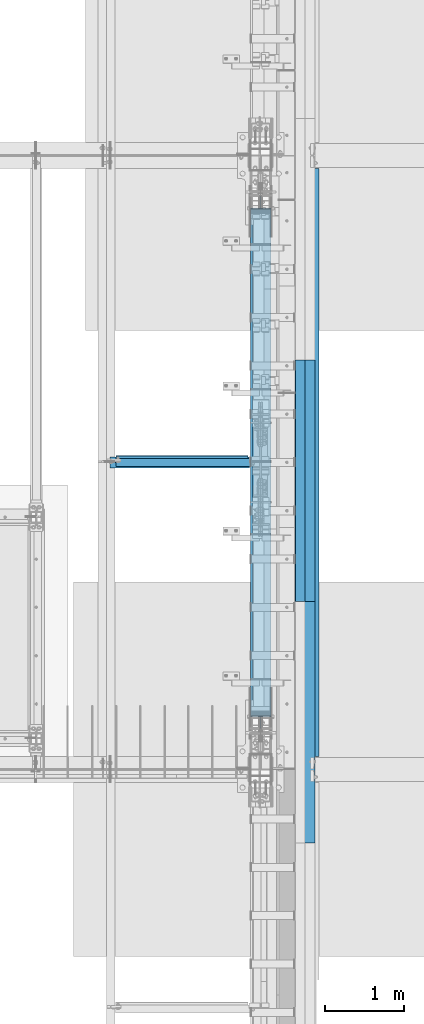
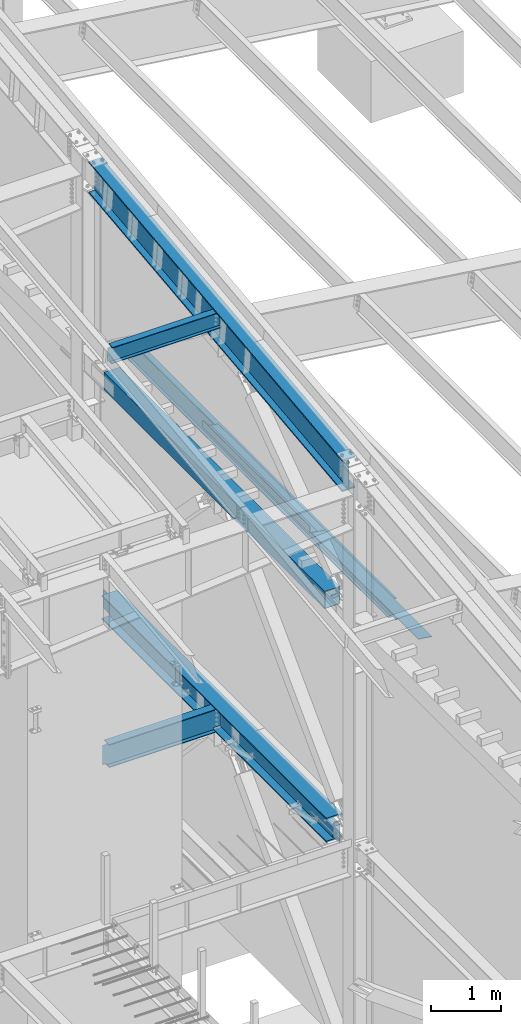
# One storey, part 724 of 1179: 9 beams, 9 elements without a shape of their own.
"""IFC2X3 building model written with IfcOpenShell, lengths in millimetres."""

from ifc_helpers import new_model, si_unit, frame, origin_with_axes, place, context, subcontext, project, spatial, faceted_brep, material, type_object, element, aggregate, save


model = new_model("IFC2X3")

# Units and contexts
model_context = context("Model", 3, precision=1e-05, world=origin_with_axes())
body_context = subcontext(model_context, "Body", "Model", "MODEL_VIEW")
ifc_project = project(units=[si_unit("LENGTHUNIT", "METRE", prefix="MILLI"), si_unit("AREAUNIT", "SQUARE_METRE"), si_unit("VOLUMEUNIT", "CUBIC_METRE"), si_unit("MASSUNIT", "GRAM", prefix="KILO"), si_unit("TIMEUNIT", "SECOND"), si_unit("PLANEANGLEUNIT", "RADIAN"), si_unit("SOLIDANGLEUNIT", "STERADIAN"), si_unit("THERMODYNAMICTEMPERATUREUNIT", "DEGREE_CELSIUS"), si_unit("LUMINOUSINTENSITYUNIT", "LUMEN")], contexts=[model_context])

# Site, building, storey
site_placement = place(None, origin_with_axes())
site = spatial("IfcSite", under=ifc_project, at=site_placement, CompositionType="ELEMENT")
building_placement = place(site_placement, origin_with_axes())
building = spatial("IfcBuilding", under=site, at=building_placement, Name="Undefined", CompositionType="ELEMENT")
storey_placement = place(building_placement, origin_with_axes())
storey = spatial("IfcBuildingStorey", under=building, at=storey_placement, Name="Undefined", CompositionType="ELEMENT", Elevation=0.0)

# Assembly, beam
assembly_1_placement = place(storey_placement, origin_with_axes())
assembly_1 = element("IfcElementAssembly", 1, at=assembly_1_placement, inside=storey, Name="BEAM", AssemblyPlace="NOTDEFINED", PredefinedType="RIGID_FRAME")
ifc_material_1 = material(Name="STEEL/A992")
beam_type_1 = type_object("IfcBeamType", Name="W16X31", PredefinedType="NOTDEFINED")
beam_1_placement = place(assembly_1_placement, frame((22323.425, 15354.3, 3900.4875), z_axis=(0.0, 0.0, 1.0), x_axis=(1.0, 0.0, 0.0)))
beam_1 = element("IfcBeam", 2, at=beam_1_placement, type_object=beam_type_1, material=ifc_material_1, Name="BEAM", ObjectType="W16X31", context=body_context, shape_type="Brep", body=[
    faceted_brep([(19.0499999999993, -3.17499999999927, -169.8625), (19.0499999999993, 3.17499999999927, -169.8625), (73.0250001907261, 3.17499999999927, -169.8625), (73.0250001907261, -3.17499999999927, -169.8625), (77.8850797087725, 3.17499999999927, -170.829229922588), (77.8850797087725, -3.17499999999927, -170.829229922588), (82.0052561769262, 3.17499999999927, -173.582243823066), (82.0052561769262, -3.17499999999927, -173.582243823066), (84.7582700774037, 3.17499999999927, -177.70242029122), (84.7582700774037, -3.17499999999927, -177.70242029122), (85.7249999999913, -3.17499999999927, -182.562499809265), (85.7249999999913, 3.17499999999927, -182.562499809265), (85.7249999999913, 3.17499999999927, -190.5), (85.7249999999913, 69.8500000000004, -190.5), (85.7249999999913, 69.8500000000004, -201.6125), (85.7249999999913, -69.8500000000004, -201.6125), (85.7249999999913, -69.8500000000004, -190.5), (85.7249999999913, -3.17499999999927, -190.5), (1842.29375, 69.8500000000004, 190.5), (1842.29375, 3.17499999999927, 190.5), (85.7249999999913, 3.17499999999927, 190.5), (85.7249999999913, 69.8500000000004, 190.5), (73.0250001907261, -3.17499999999927, 169.8625), (73.0250001907261, 3.17499999999927, 169.8625), (19.0500000762049, 3.17499999999382, 169.8625), (19.0499999238054, -3.17500000000564, 169.8625), (77.8850797087725, -3.17499999999927, 170.829229922588), (77.8850797087725, 3.17499999999927, 170.829229922588), (82.0052561769262, -3.17499999999927, 173.582243823066), (82.0052561769262, 3.17499999999927, 173.582243823066), (84.7582700774037, -3.17499999999927, 177.702420291219), (84.7582700774037, 3.17499999999927, 177.702420291219), (85.7249999999913, -3.17499999999927, 182.562499809265), (85.7249999999913, 3.17499999999927, 182.562499809265), (1842.29375, -69.8500000000004, 201.6125), (1842.29375, 69.8500000000004, 201.6125), (85.7249999999913, 69.8500000000004, 201.6125), (85.7249999999913, -69.8500000000004, 201.6125), (1842.29375, -69.8500000000004, 190.5), (85.7249999999913, -69.8500000000004, 190.5), (1842.29375, -3.17499999999927, 190.5), (85.7249999999913, -3.17499999999927, 190.5), (1842.29375, -3.17499999999927, 169.862499809265), (1842.29375, 3.17499999999927, 169.862499809265), (1843.26047992258, -3.17499999999927, 165.00242029122), (1843.26047992258, 3.17499999999927, 165.00242029122), (1846.01349382306, -3.17499999999927, 160.882243823066), (1846.01349382306, 3.17499999999927, 160.882243823066), (1850.13367029122, -3.17499999999927, 158.129229922588), (1850.13367029122, 3.17499999999927, 158.129229922588), (1854.99374980926, -3.17499999999927, 157.1625), (1854.99374980926, 3.17499999999927, 157.1625), (1966.11875, -3.17499999999927, 157.1625), (1966.11875, 3.17499999999927, 157.1625), (1966.11875, -3.17499999999927, -157.1625), (1966.11875, 3.17499999999927, -157.1625), (1854.99374980926, -3.17499999999927, -157.1625), (1854.99374980926, 3.17499999999927, -157.1625), (1850.13367029122, -3.17499999999927, -158.129229922588), (1850.13367029122, 3.17499999999927, -158.129229922588), (1846.01349382306, -3.17499999999927, -160.882243823066), (1846.01349382306, 3.17499999999927, -160.882243823066), (1843.26047992258, -3.17499999999927, -165.00242029122), (1843.26047992258, 3.17499999999927, -165.00242029122), (1842.29375, -3.17499999999927, -169.862499809266), (1842.29375, 3.17499999999927, -169.862499809266), (1842.29375, -3.17499999999927, -190.5), (1842.29375, -69.8500000000004, -190.5), (1842.29375, -69.8500000000004, -201.6125), (1842.29375, 69.8500000000004, -201.6125), (1842.29375, 69.8500000000004, -190.5), (1842.29375, 3.17499999999927, -190.5)], [[[0, 1, 2, 3]], [[3, 2, 4, 5]], [[5, 4, 6, 7]], [[7, 6, 8, 9]], [[10, 11, 12, 13, 14, 15, 16, 17]], [[9, 8, 11, 10]], [[18, 19, 20, 21]], [[22, 23, 24, 25]], [[26, 27, 23, 22]], [[28, 29, 27, 26]], [[30, 31, 29, 28]], [[32, 33, 31, 30]], [[34, 35, 36, 37]], [[38, 34, 37, 39]], [[40, 38, 39, 41]], [[37, 36, 21, 20, 33, 32, 41, 39]], [[35, 18, 21, 36]], [[34, 38, 40, 42, 43, 19, 18, 35]], [[44, 45, 43, 42]], [[46, 47, 45, 44]], [[48, 49, 47, 46]], [[50, 51, 49, 48]], [[52, 53, 51, 50]], [[53, 52, 54, 55]], [[54, 56, 57, 55]], [[58, 59, 57, 56]], [[60, 61, 59, 58]], [[62, 63, 61, 60]], [[64, 65, 63, 62]], [[66, 67, 68, 69, 70, 71, 65, 64]], [[67, 66, 17, 16]], [[68, 67, 16, 15]], [[69, 68, 15, 14]], [[70, 69, 14, 13]], [[71, 70, 13, 12]], [[6, 4, 2, 1, 24, 23, 27, 29, 31, 33, 20, 19, 43, 45, 47, 49, 51, 53, 55, 57, 59, 61, 63, 65, 71, 12, 11, 8]], [[25, 24, 1, 0]], [[66, 64, 62, 60, 58, 56, 54, 52, 50, 48, 46, 44, 42, 40, 41, 32, 30, 28, 26, 22, 25, 0, 3, 5, 7, 9, 10, 17]]]),
])
aggregate(assembly_1, [beam_1])

assembly_2_placement = place(storey_placement, origin_with_axes())
assembly_2 = element("IfcElementAssembly", 3, at=assembly_2_placement, inside=storey, Name="PLATE", AssemblyPlace="NOTDEFINED", PredefinedType="RIGID_FRAME")
ifc_material_2 = material(Name="STEEL/A36")
beam_type_2 = type_object("IfcBeamType", PredefinedType="NOTDEFINED")
beam_2_placement = place(assembly_2_placement, frame((24880.9652345644, 13601.6999999996, 7964.0487255808), z_axis=(-0.99100656978554, 0.0, 0.133813222971043), x_axis=(0.0, 1.0, 0.0)))
beam_2 = element("IfcBeam", 4, at=beam_2_placement, type_object=beam_type_2, material=ifc_material_2, Name="PLATE", context=body_context, shape_type="Brep", body=[
    faceted_brep([(0.0, 4.76249999999709, -114.3), (0.0, 4.76249999999709, 114.3), (3048.0, 4.76249999996799, 114.300000000025), (3048.0, 4.76250000002983, -114.300000000025), (0.0, -4.76249999999709, 114.3), (3048.0, -4.76250000003711, 114.300000000014), (0.0, -4.76249999999709, -114.3), (3048.0, -4.76249999997344, -114.300000000036)], [[[0, 1, 2, 3]], [[1, 4, 5, 2]], [[4, 6, 7, 5]], [[6, 0, 3, 7]], [[5, 7, 3, 2]], [[6, 4, 1, 0]]]),
])
aggregate(assembly_2, [beam_2])

assembly_3_placement = place(storey_placement, origin_with_axes())
assembly_3 = element("IfcElementAssembly", 5, at=assembly_3_placement, inside=storey, Name="PLATE", AssemblyPlace="NOTDEFINED", PredefinedType="RIGID_FRAME")
beam_3_placement = place(assembly_3_placement, frame((24880.9652345644, 10553.6999999996, 7964.0487255808), z_axis=(-0.99100656978554, 0.0, 0.133813222971043), x_axis=(0.0, 1.0, 0.0)))
beam_3 = element("IfcBeam", 6, at=beam_3_placement, type_object=beam_type_2, material=ifc_material_2, Name="PLATE", context=body_context, shape_type="Brep", body=[
    faceted_brep([(0.0, 4.76249999999709, -114.3), (0.0, 4.76249999999709, 114.3), (3048.0, 4.76249999996799, 114.300000000025), (3048.0, 4.76250000002983, -114.300000000025), (0.0, -4.76249999999709, 114.3), (3048.0, -4.76250000003711, 114.300000000014), (0.0, -4.76249999999709, -114.3), (3048.0, -4.76249999997344, -114.300000000036)], [[[0, 1, 2, 3]], [[1, 4, 5, 2]], [[4, 6, 7, 5]], [[6, 0, 3, 7]], [[5, 7, 3, 2]], [[6, 4, 1, 0]]]),
])
aggregate(assembly_3, [beam_3])

assembly_4_placement = place(storey_placement, origin_with_axes())
assembly_4 = element("IfcElementAssembly", 7, at=assembly_4_placement, inside=storey, Name="BENT_PLATE", AssemblyPlace="NOTDEFINED", PredefinedType="RIGID_FRAME")
beam_type_3 = type_object("IfcBeamType", PredefinedType="NOTDEFINED")
beam_4_placement = place(assembly_4_placement, frame((24744.362499997, 15125.6999999996, 8102.29217706219), z_axis=(0.0, 1.0, 0.0), x_axis=(0.0, 0.0, -1.0)))
beam_4 = element("IfcBeam", 8, at=beam_4_placement, type_object=beam_type_3, material=ifc_material_2, Name="BENT_PLATE", context=body_context, shape_type="Brep", body=[
    faceted_brep([(-2.91038304567337e-11, -4.76250000000073, -1524.0), (-2.91038304567337e-11, -4.76250000000073, 1524.0), (2.91038304567337e-11, 4.76250000000073, 1524.0), (2.91038304567337e-11, 4.76250000000073, -1524.0), (114.300008765535, 4.76250001759399, 1524.0000000001), (114.300003051474, 4.7625000005828, -1524.0), (105.977955544956, -4.76249999945867, -1524.0), (105.977955544956, -4.76249999945867, 1524.0), (131.343048095475, -121.088742065571, 1524.0), (131.343048095475, -121.088742065571, -1524.0), (121.904205090902, -122.366970423507, 1524.0), (121.904205090902, -122.366970423507, -1524.0)], [[[0, 1, 2, 3]], [[3, 2, 4, 5]], [[1, 0, 6, 7]], [[5, 4, 8, 9]], [[4, 2, 1, 7, 10, 8]], [[7, 6, 11, 10]], [[6, 0, 3, 5, 9, 11]], [[10, 11, 9, 8]]]),
])
aggregate(assembly_4, [beam_4])

assembly_5_placement = place(storey_placement, origin_with_axes())
assembly_5 = element("IfcElementAssembly", 9, at=assembly_5_placement, inside=storey, Name="BEAM", AssemblyPlace="NOTDEFINED", PredefinedType="RIGID_FRAME")
beam_type_4 = type_object("IfcBeamType", Name="W12X22", PredefinedType="NOTDEFINED")
beam_5_placement = place(assembly_5_placement, frame((22415.5, 15371.7685968403, 10827.304499945), z_axis=(0.0, -0.112284087038017, 0.993676146336441), x_axis=(1.0, 0.0, 0.0)))
beam_5 = element("IfcBeam", 10, at=beam_5_placement, type_object=beam_type_4, material=ifc_material_1, Name="BEAM", ObjectType="W12X22", context=body_context, shape_type="Brep", body=[
    faceted_brep([(15.875, -3.17500000004293, -130.175000001276), (15.875, 3.17499999995198, -130.175000001278), (50.8000001907349, 3.17499998291896, -130.175000001278), (50.8000001907349, -3.17500000004293, -130.175000001276), (55.6600797087813, 3.17499998284256, -131.141729923866), (55.6600797087813, -3.17500000004293, -131.141729923862), (59.7802561769349, 3.17499998263156, -133.894743824338), (59.7802561769349, -3.17500000004293, -133.894743824334), (62.5332700774125, 3.17499998230778, -138.014920292484), (62.5332700774125, -3.17500000004657, -138.014920292482), (63.5, -3.17500000004657, -142.874999810521), (63.5, 3.17499998193671, -142.874999810523), (63.5, 3.17499995250182, -144.46249999992), (63.5, 50.7999999999192, -144.46249999994), (63.5, 50.7999999999156, -155.574999999932), (63.5, -50.8000000000284, -155.574999999892), (63.5, -50.8000000000247, -144.462499999896), (63.5, -3.1750000000502, -144.462499999914), (1732.75625, 3.17499999994834, -144.46249999992), (1732.75625, 3.17499999999563, -155.574999999912), (1732.75625, 50.7999999999156, -155.574999999932), (1732.75625, 50.7999999999192, -144.46249999994), (1872.45625, 3.17499999994834, -144.46249999992), (1872.45625, 3.17499999999563, -155.574999999912), (1770.85625, 50.8000000000357, 144.4624999999), (1770.85625, 3.17500000006476, 144.462499999918), (63.5, 3.17500000006476, 144.462499999918), (63.5, 50.8000000000357, 144.4624999999), (50.8000001907349, -3.17499999994106, 130.174999998288), (50.8000001907349, 3.17500000292785, 130.174999998286), (15.875, 3.17500000005748, 130.174999998284), (15.875, -3.17499999994106, 130.174999998288), (55.6600797087813, -3.17499999993379, 131.141729920873), (55.6600797087813, 3.17500000300424, 131.141729920872), (59.7802561769349, -3.17499999993743, 133.894743821347), (59.7802561769349, 3.17500000321525, 133.894743821344), (62.5332700774125, -3.17499999993379, 138.014920289494), (62.5332700774125, 3.17500000353539, 138.014920289492), (63.5, -3.17499999993015, 142.874999807531), (63.5, 3.1750000039101, 142.874999807529), (1770.85625, -50.799999999901, 155.574999999935), (1770.85625, 50.8000000000429, 155.574999999893), (63.5, 50.8000000000429, 155.574999999893), (63.5, -50.799999999901, 155.574999999935), (1770.85625, -50.7999999999047, 144.462499999941), (63.5, -50.7999999999047, 144.462499999941), (1770.85625, -3.17499999993379, 144.462499999923), (63.5, -3.17499999993379, 144.462499999923), (1770.85625, -3.17499999993743, 130.174999807548), (1770.85625, 3.17500000005748, 130.174999807547), (1771.82297992259, -3.17499999993743, 125.314920289511), (1771.82297992259, 3.17500000005748, 125.314920289509), (1774.57599382307, -3.1749999999447, 121.194743821365), (1774.57599382307, 3.17500000005384, 121.194743821363), (1778.69617029122, -3.1749999999447, 118.441729920891), (1778.69617029122, 3.17500000005384, 118.441729920889), (1783.55624980927, -3.1749999999447, 117.474999998307), (1783.55624980927, 3.17500000005384, 117.474999998303), (1872.45625, -3.1749999999447, 117.474999998307), (1872.45625, 3.17500000005384, 117.474999998303), (1872.45625, -3.1750000000502, -144.462499999914), (1872.45625, -50.8000000000247, -144.462499999896), (1872.45625, -50.8000000000284, -155.574999999892)], [[[0, 1, 2, 3]], [[3, 2, 4, 5]], [[5, 4, 6, 7]], [[7, 6, 8, 9]], [[10, 11, 12, 13, 14, 15, 16, 17]], [[9, 8, 11, 10]], [[18, 19, 20, 21]], [[22, 23, 19, 18]], [[24, 25, 26, 27]], [[28, 29, 30, 31]], [[32, 33, 29, 28]], [[34, 35, 33, 32]], [[36, 37, 35, 34]], [[38, 39, 37, 36]], [[40, 41, 42, 43]], [[44, 40, 43, 45]], [[46, 44, 45, 47]], [[43, 42, 27, 26, 39, 38, 47, 45]], [[41, 24, 27, 42]], [[40, 44, 46, 48, 49, 25, 24, 41]], [[50, 51, 49, 48]], [[52, 53, 51, 50]], [[54, 55, 53, 52]], [[56, 57, 55, 54]], [[58, 59, 57, 56]], [[60, 61, 62, 23, 22, 59, 58]], [[61, 60, 17, 16]], [[62, 61, 16, 15]], [[20, 19, 23, 62, 15, 14]], [[21, 20, 14, 13]], [[18, 21, 13, 12]], [[6, 4, 2, 1, 30, 29, 33, 35, 37, 39, 26, 25, 49, 51, 53, 55, 57, 59, 22, 18, 12, 11, 8]], [[31, 30, 1, 0]], [[60, 58, 56, 54, 52, 50, 48, 46, 47, 38, 36, 34, 32, 28, 31, 0, 3, 5, 7, 9, 10, 17]]]),
])
aggregate(assembly_5, [beam_5])

assembly_6_placement = place(storey_placement, origin_with_axes())
assembly_6 = element("IfcElementAssembly", 11, at=assembly_6_placement, inside=storey, Name="BEAM", AssemblyPlace="NOTDEFINED", PredefinedType="RIGID_FRAME")
beam_6_placement = place(assembly_6_placement, frame((24972.7820076571, 11480.8, 7789.85835826085), z_axis=(0.133813223953133, 0.0, 0.991006569652931), x_axis=(0.0, 1.0, 0.0)))
beam_6 = element("IfcBeam", 12, at=beam_6_placement, type_object=beam_type_4, material=ifc_material_1, Name="BEAM", ObjectType="W12X22", context=body_context, shape_type="Brep", body=[
    faceted_brep([(7585.075, -3.17499999982829, -144.462500000047), (7585.075, -50.7999999998428, -144.46250000006), (7585.075, -50.7999999998356, -155.575000000064), (7585.075, 50.8000000001921, -155.575000000037), (7585.075, 50.8000000001775, -144.462500000032), (7585.075, 3.17500000017026, -144.462500000047), (7585.075, 3.17500000016298, -136.524999801413), (7585.075, -3.17499999984284, -136.52499980141), (7586.04172992259, 3.17500000014843, -131.664920283363), (7586.04172992259, -3.17499999984284, -131.66492028336), (7588.79474382307, 3.17500000014843, -127.544743815206), (7588.79474382307, -3.17499999985012, -127.544743815202), (7592.91492029122, 3.17500000014843, -124.791729914725), (7592.91492029122, -3.17499999985012, -124.791729914721), (7597.77499980927, 3.17500000014115, -123.824999992135), (7597.77499980927, -3.17499999985739, -123.824999992132), (7726.3625, -3.17499999985739, -123.824999992028), (7726.3625, 3.17500000014115, -123.824999992019), (165.100000000002, 3.17499999982829, 144.462500000052), (165.100000000002, 50.7999999998356, 144.462500000065), (7585.075, 50.7999999998356, 144.462500000065), (7585.075, 3.17499999982829, 144.462500000052), (165.100000000002, -3.17499999984284, -136.524999799762), (165.100000000002, 3.17500000016298, -136.524999799765), (165.100000000002, 3.17500000017026, -144.462500000047), (165.100000000002, 50.8000000001775, -144.462500000032), (165.100000000002, 50.8000000001921, -155.575000000037), (165.100000000002, -50.7999999998356, -155.575000000064), (165.100000000002, -50.7999999998428, -144.46250000006), (165.100000000002, -3.17499999982829, -144.462500000047), (164.133270077415, -3.17499999984284, -131.664920281712), (164.133270077415, 3.17500000014843, -131.664920281715), (161.380256176937, -3.17499999985739, -127.544743813552), (161.380256176937, 3.17500000014843, -127.544743813558), (157.260079708783, -3.17499999985739, -124.791729913073), (157.260079708783, 3.17500000014115, -124.791729913077), (152.400000190737, -3.17499999985739, -123.824999990484), (152.400000190737, 3.17500000014843, -123.824999990487), (20.6375000000044, -3.17499999985739, -123.824999990466), (20.6375000000044, 3.17500000014843, -123.824999990458), (20.6375000000044, -3.17500000014115, 117.475000009781), (20.6375000000044, 3.17499999986467, 117.475000009788), (152.400000190737, -3.17500000014115, 117.475000009763), (152.400000190737, 3.17499999985739, 117.475000009759), (157.260079708783, -3.17500000014115, 118.44172993235), (157.260079708783, 3.17499999986467, 118.441729932347), (161.380256176937, -3.17500000014115, 121.194743832832), (161.380256176937, 3.17499999985739, 121.194743832826), (164.133270077415, -3.17500000014843, 125.314920300991), (164.133270077415, 3.17499999985012, 125.314920300985), (165.100000000002, -3.17500000016298, 130.174999819041), (165.100000000002, 3.17499999984284, 130.174999819037), (165.100000000002, -50.8000000001994, 155.575000000043), (165.100000000002, 50.7999999998283, 155.57500000007), (165.100000000002, -3.17500000017753, 144.462500000051), (165.100000000002, -50.8000000001775, 144.462500000036), (7585.075, -3.17500000017753, 144.462500000051), (7585.075, -50.8000000001775, 144.462500000036), (7585.075, -50.8000000001994, 155.575000000043), (7585.075, 50.7999999998283, 155.57500000007), (7585.075, -3.17500000015571, 130.174999817393), (7585.075, 3.17499999985012, 130.174999817389), (7586.04172992259, -3.17500000015571, 125.314920299345), (7586.04172992259, 3.17499999985012, 125.314920299339), (7588.79474382307, -3.17500000014843, 121.194743831185), (7588.79474382307, 3.17499999985739, 121.194743831182), (7592.91492029122, -3.17500000014115, 118.441729930704), (7592.91492029122, 3.17499999986467, 118.441729930701), (7597.77499980927, -3.17500000014115, 117.475000008117), (7597.77499980927, 3.17499999986467, 117.475000008111), (7726.3625, -3.17500000014115, 117.47500000822), (7726.3625, 3.17499999985739, 117.475000008229)], [[[0, 1, 2, 3, 4, 5, 6, 7]], [[7, 6, 8, 9]], [[9, 8, 10, 11]], [[11, 10, 12, 13]], [[13, 12, 14, 15]], [[16, 15, 14, 17]], [[18, 19, 20, 21]], [[22, 23, 24, 25, 26, 27, 28, 29]], [[30, 31, 23, 22]], [[32, 33, 31, 30]], [[34, 35, 33, 32]], [[36, 37, 35, 34]], [[38, 39, 37, 36]], [[40, 41, 39, 38]], [[42, 43, 41, 40]], [[44, 45, 43, 42]], [[46, 47, 45, 44]], [[48, 49, 47, 46]], [[50, 51, 49, 48]], [[52, 53, 19, 18, 51, 50, 54, 55]], [[55, 54, 56, 57]], [[52, 55, 57, 58]], [[53, 52, 58, 59]], [[19, 53, 59, 20]], [[58, 57, 56, 60, 61, 21, 20, 59]], [[62, 63, 61, 60]], [[64, 65, 63, 62]], [[66, 67, 65, 64]], [[68, 69, 67, 66]], [[70, 71, 69, 68]], [[71, 70, 16, 17]], [[12, 10, 8, 6, 5, 24, 23, 31, 33, 35, 37, 39, 41, 43, 45, 47, 49, 51, 18, 21, 61, 63, 65, 67, 69, 71, 17, 14]], [[25, 24, 5, 4]], [[26, 25, 4, 3]], [[27, 26, 3, 2]], [[28, 27, 2, 1]], [[29, 28, 1, 0]], [[70, 68, 66, 64, 62, 60, 56, 54, 50, 48, 46, 44, 42, 40, 38, 36, 34, 32, 30, 22, 29, 0, 7, 9, 11, 13, 15, 16]]]),
])
aggregate(assembly_6, [beam_6])

assembly_7_placement = place(storey_placement, origin_with_axes())
assembly_7 = element("IfcElementAssembly", 13, at=assembly_7_placement, inside=storey, Name="BEAM", AssemblyPlace="NOTDEFINED", PredefinedType="RIGID_FRAME")
beam_type_5 = type_object("IfcBeamType", Name="W21X93", PredefinedType="NOTDEFINED")
beam_7_placement = place(assembly_7_placement, frame((24307.8, 11511.6467563166, 10271.2956244622), z_axis=(0.0, -0.112284087038017, 0.993676146336441), x_axis=(0.0, 0.993676146336441, 0.112284087038017)))
beam_7 = element("IfcBeam", 14, at=beam_7_placement, type_object=beam_type_5, material=ifc_material_1, Name="BEAM", ObjectType="W21X93", context=body_context, shape_type="Brep", body=[
    faceted_brep([(199.930151815766, -106.362499999999, -274.637499999924), (199.930151815766, 106.362499999999, -274.637499999924), (7473.81664542463, 106.362499999999, -274.637500002875), (7473.81664542463, -106.362499999999, -274.637500002875), (202.620932743182, -106.362499999999, -250.824999999939), (202.620932743182, -7.14374999999927, -250.824999999939), (259.306717614098, -7.14374999999927, 250.824999999757), (259.306717614098, -106.362499999999, 250.824999999757), (261.997498541514, -106.362499999999, 274.637499999742), (261.997498541514, 106.362499999999, 274.637499999742), (259.306717614098, 106.362499999999, 250.824999999757), (259.306717614098, 7.14374999999927, 250.824999999757), (259.165541301165, 7.14374999999927, 249.575637438333), (214.511782852362, 7.14374999999927, -145.595003258246), (202.620932743182, 7.14374999999927, -250.824999999939), (202.620932743182, 106.362499999999, -250.824999999939), (7476.50742635205, -106.362499999999, -250.825000002889), (7476.50742635205, -7.14374999999927, -250.825000002889), (7533.19321122296, -7.14374999999927, 250.824999996807), (7533.19321122296, -106.362499999999, 250.824999996807), (7535.88399215038, -106.362499999999, 274.637499996792), (7535.88399215038, 106.362499999999, 274.637499996792), (7533.19321122296, 106.362499999999, 250.824999996807), (7533.19321122296, 7.14374999999927, 250.824999996807), (7527.16214315235, 7.14374999999927, 197.452089936314), (7482.5083847036, 7.14374999999927, -197.718550759804), (7476.50742635205, 7.14374999999927, -250.825000002889), (7476.50742635205, 106.362499999999, -250.825000002889)], [[[0, 1, 2, 3]], [[0, 4, 5, 6, 7, 8, 9, 10, 11, 12, 13, 14, 15, 1]], [[5, 4, 16, 17]], [[6, 5, 17, 18]], [[7, 6, 18, 19]], [[8, 7, 19, 20]], [[9, 8, 20, 21]], [[10, 9, 21, 22]], [[11, 10, 22, 23]], [[14, 13, 12, 11, 23, 24, 25, 26]], [[15, 14, 26, 27]], [[1, 15, 27, 2]], [[26, 25, 24, 23, 22, 21, 20, 19, 18, 17, 16, 3, 2, 27]], [[4, 0, 3, 16]]]),
])
aggregate(assembly_7, [beam_7])

assembly_8_placement = place(storey_placement, origin_with_axes())
assembly_8 = element("IfcElementAssembly", 15, at=assembly_8_placement, inside=storey, Name="BEAM", AssemblyPlace="NOTDEFINED", PredefinedType="RIGID_FRAME")
beam_type_6 = type_object("IfcBeamType", Name="W16X77", PredefinedType="NOTDEFINED")
beam_8_placement = place(assembly_8_placement, frame((24307.8, 11480.8, 3892.55), z_axis=(0.0, 0.0, 1.0), x_axis=(0.0, 1.0, 0.0)))
beam_8 = element("IfcBeam", 16, at=beam_8_placement, type_object=beam_type_6, material=ifc_material_1, Name="BEAM", ObjectType="W16X77", context=body_context, shape_type="Brep", body=[
    faceted_brep([(673.322012253266, -130.174999999999, 209.55), (673.322012253266, 130.174999999999, 209.55), (662.323433080543, 130.174999999999, 190.5), (662.323433080543, 5.55625000000146, 190.5), (662.09422384529, 5.55625000000146, 190.103), (662.09422384529, -5.55625000000146, 190.103), (662.323433080543, -5.55625000000146, 190.5), (662.323433080543, -130.174999999999, 190.5), (705.186430723774, -5.55625000000146, 190.103), (705.186430723774, 5.55625000000146, 190.103), (719.762794920778, 5.55625000000146, 183.243356973128), (719.762794920778, -5.55625000000146, 183.243356973128), (723.618543529823, 5.55625000000146, 179.929052423034), (723.618543529823, -5.55625000000146, 179.929052423034), (725.219970004571, 5.55625000000146, 175.103407882363), (725.219970004571, -5.55625000000146, 175.103407882363), (724.11076292384, 5.55625000000146, 170.141445403767), (724.11076292384, -5.55625000000146, 170.141445403767), (720.606980419159, 5.55625000000146, 166.457029554975), (720.606980419159, -5.55625000000146, 166.457029554975), (715.706992381027, 5.55625000000146, 165.1), (715.706992381027, -5.55625000000146, 165.1), (513.098430723774, 5.55625000000146, 165.1), (513.098430723774, -5.55625000000146, 165.1), (513.098430723774, 5.55625000000146, -165.1), (513.098430723774, -5.55625000000146, -165.1), (716.050992381026, 5.55625000000146, -165.1), (716.050992381026, -5.55625000000146, -165.1), (720.95098041916, 5.55625000000146, -166.457029554975), (720.95098041916, -5.55625000000146, -166.457029554975), (724.45476292384, 5.55625000000146, -170.141445403767), (724.45476292384, -5.55625000000146, -170.141445403767), (725.563970004572, 5.55625000000146, -175.103407882363), (725.563970004572, -5.55625000000146, -175.103407882363), (723.962543529824, 5.55625000000146, -179.929052423034), (723.962543529824, -5.55625000000146, -179.929052423034), (720.106794920777, 5.55625000000146, -183.243356973128), (720.106794920777, -5.55625000000146, -183.243356973128), (705.530430723771, 5.55625000000146, -190.103), (705.530430723771, -5.55625000000146, -190.103), (673.551229493032, 5.55625000000146, -190.103), (673.551229493032, -5.55625000000146, -190.103), (7073.6779721386, 5.55625000000146, -190.5), (7073.6779721386, 130.174999999999, -190.5), (673.322028262293, 130.174999999999, -190.5), (673.322028262293, 5.55625000000146, -190.5), (7084.67616721564, 130.174999999999, -209.55), (662.323833185252, 130.174999999999, -209.55), (7084.67616721564, -130.174999999999, -209.55), (662.323833185252, -130.174999999999, -209.55), (7073.6779721386, -130.174999999999, -190.5), (673.322028262293, -130.174999999999, -190.5), (673.322028262293, -5.55625000000146, -190.5), (7073.6779721386, -5.55625000000146, -190.5), (7073.44877090786, 5.55625000000146, -190.103), (7073.44877090786, -5.55625000000146, -190.103), (7041.46956967712, 5.55625000000146, -190.103), (7041.46956967712, -5.55625000000146, -190.103), (7026.89320548012, 5.55625000000146, -183.243356973127), (7026.89320548012, -5.55625000000146, -183.243356973127), (7023.03745687107, 5.55625000000146, -179.929052423033), (7023.03745687107, -5.55625000000146, -179.929052423033), (7021.43603039632, 5.55625000000146, -175.103407882362), (7021.43603039632, -5.55625000000146, -175.103407882362), (7022.54523747705, 5.55625000000146, -170.141445403767), (7022.54523747705, -5.55625000000146, -170.141445403767), (7026.04901998173, 5.55625000000146, -166.457029554975), (7026.04901998173, -5.55625000000146, -166.457029554975), (7030.94900801987, 5.55625000000146, -165.1), (7030.94900801987, -5.55625000000146, -165.1), (7233.90156967712, 5.55625000000146, -165.1), (7233.90156967712, -5.55625000000146, -165.1), (7233.90156967712, -5.55625000000146, 165.1), (7233.90156967712, 5.55625000000146, 165.1), (7031.29300801987, 5.55625000000146, 165.1), (7031.29300801987, -5.55625000000146, 165.1), (7026.39301998173, 5.55625000000146, 166.457029554973), (7026.39301998173, -5.55625000000146, 166.457029554973), (7022.88923747705, 5.55625000000146, 170.141445403766), (7022.88923747705, -5.55625000000146, 170.141445403766), (7021.78003039632, 5.55625000000146, 175.103407882361), (7021.78003039632, -5.55625000000146, 175.103407882361), (7023.38145687107, 5.55625000000146, 179.929052423033), (7023.38145687107, -5.55625000000146, 179.929052423033), (7027.23720548012, 5.55625000000146, 183.243356973128), (7027.23720548012, -5.55625000000146, 183.243356973128), (7041.81356967712, 5.55625000000146, 190.103), (7041.81356967712, -5.55625000000146, 190.103), (7084.9057765556, 5.55625000000146, 190.103), (7084.9057765556, -5.55625000000146, 190.103), (7084.67656732035, -130.174999999999, 190.5), (7084.67656732035, -5.55625000000146, 190.5), (7084.67656732035, 5.55625000000146, 190.5), (7084.67656732035, 130.174999999999, 190.5), (7073.67798814763, 130.174999999999, 209.55), (7073.67798814763, -130.174999999999, 209.55)], [[[0, 1, 2, 3, 4, 5, 6, 7]], [[8, 9, 10, 11]], [[11, 10, 12, 13]], [[13, 12, 14, 15]], [[15, 14, 16, 17]], [[17, 16, 18, 19]], [[19, 18, 20, 21]], [[21, 20, 22, 23]], [[23, 22, 24, 25]], [[26, 27, 25, 24]], [[27, 26, 28, 29]], [[29, 28, 30, 31]], [[31, 30, 32, 33]], [[33, 32, 34, 35]], [[35, 34, 36, 37]], [[37, 36, 38, 39]], [[39, 38, 40, 41]], [[42, 43, 44, 45]], [[43, 46, 47, 44]], [[46, 48, 49, 47]], [[48, 50, 51, 49]], [[41, 40, 45, 44, 47, 49, 51, 52]], [[50, 53, 52, 51]], [[48, 46, 43, 42, 54, 55, 53, 50]], [[56, 57, 55, 54]], [[57, 56, 58, 59]], [[59, 58, 60, 61]], [[61, 60, 62, 63]], [[63, 62, 64, 65]], [[65, 64, 66, 67]], [[67, 66, 68, 69]], [[69, 68, 70, 71]], [[72, 71, 70, 73]], [[74, 75, 72, 73]], [[75, 74, 76, 77]], [[77, 76, 78, 79]], [[79, 78, 80, 81]], [[81, 80, 82, 83]], [[83, 82, 84, 85]], [[85, 84, 86, 87]], [[87, 86, 88, 89]], [[90, 91, 89, 88, 92, 93, 94, 95]], [[90, 95, 0, 7]], [[91, 90, 7, 6]], [[8, 11, 13, 15, 17, 19, 21, 23, 25, 27, 29, 31, 33, 35, 37, 39, 41, 52, 53, 55, 57, 59, 61, 63, 65, 67, 69, 71, 72, 75, 77, 79, 81, 83, 85, 87, 89, 91, 6, 5]], [[9, 8, 5, 4]], [[92, 88, 86, 84, 82, 80, 78, 76, 74, 73, 70, 68, 66, 64, 62, 60, 58, 56, 54, 42, 45, 40, 38, 36, 34, 32, 30, 28, 26, 24, 22, 20, 18, 16, 14, 12, 10, 9, 4, 3]], [[93, 92, 3, 2]], [[94, 93, 2, 1]], [[95, 94, 1, 0]]]),
])
aggregate(assembly_8, [beam_8])

assembly_9_placement = place(storey_placement, origin_with_axes())
assembly_9 = element("IfcElementAssembly", 17, at=assembly_9_placement, inside=storey, Name="BEAM", AssemblyPlace="NOTDEFINED", PredefinedType="RIGID_FRAME")
ifc_material_3 = material()
beam_type_7 = type_object("IfcBeamType", Name="HSS12X10X1/2", PredefinedType="NOTDEFINED")
beam_9_placement = place(assembly_9_placement, frame((24307.8, 12198.1751974617, 7861.30000000035), z_axis=(0.0, 0.0, 1.0), x_axis=(0.0, 1.0, 0.0)))
beam_9 = element("IfcBeam", 18, at=beam_9_placement, type_object=beam_type_7, material=ifc_material_3, Name="BEAM", ObjectType="HSS12X10X1/2", context=body_context, shape_type="Brep", body=[
    faceted_brep([(9.52500000000146, 114.299999999999, -139.7), (9.52500000000146, -114.299999999999, -139.7), (6302.72460605218, -114.299999999999, -139.7), (6302.72460605218, 114.299999999999, -139.7), (9.52500000000146, -114.299999999999, 139.7), (6302.72460605218, -114.299999999999, 139.7), (9.52500000000146, 114.299999999999, 139.7), (6302.72460605218, 114.299999999999, 139.7), (9.52500000000146, 127.0, -152.4), (9.52500000000146, 127.0, 152.4), (6302.72460605218, 127.0, 152.4), (6302.72460605218, 127.0, -152.4), (9.52500000000146, -127.0, 152.4), (6302.72460605218, -127.0, 152.4), (9.52500000000146, -127.0, -152.4), (6302.72460605218, -127.0, -152.4)], [[[0, 1, 2, 3]], [[1, 4, 5, 2]], [[4, 6, 7, 5]], [[6, 0, 3, 7]], [[8, 9, 10, 11]], [[9, 12, 13, 10]], [[12, 14, 15, 13]], [[14, 8, 11, 15]], [[13, 15, 11, 10], [5, 7, 3, 2]], [[14, 12, 9, 8], [6, 4, 1, 0]]]),
])
aggregate(assembly_9, [beam_9])

save(model, "model.ifc")
